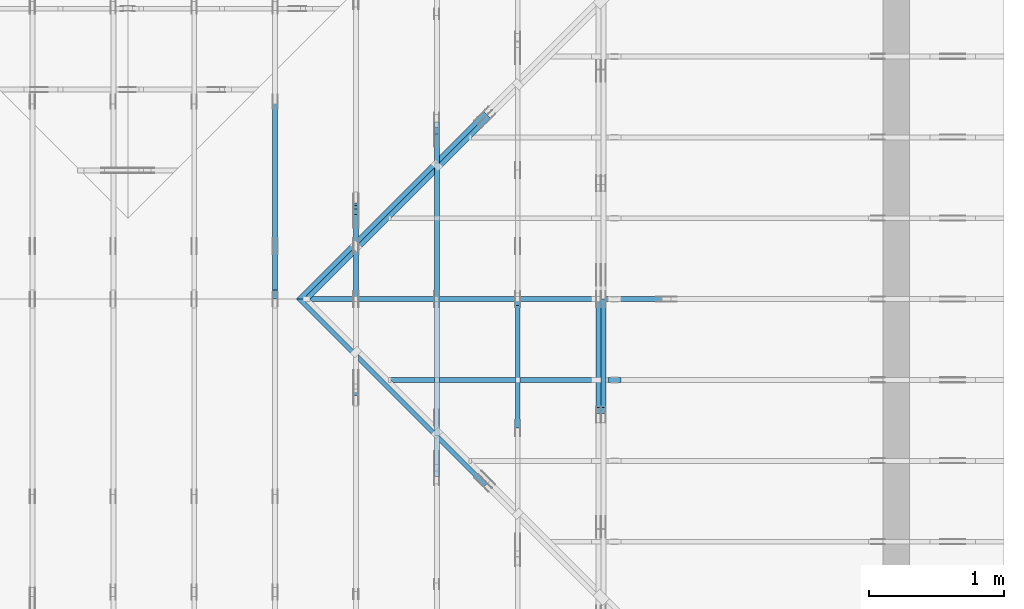
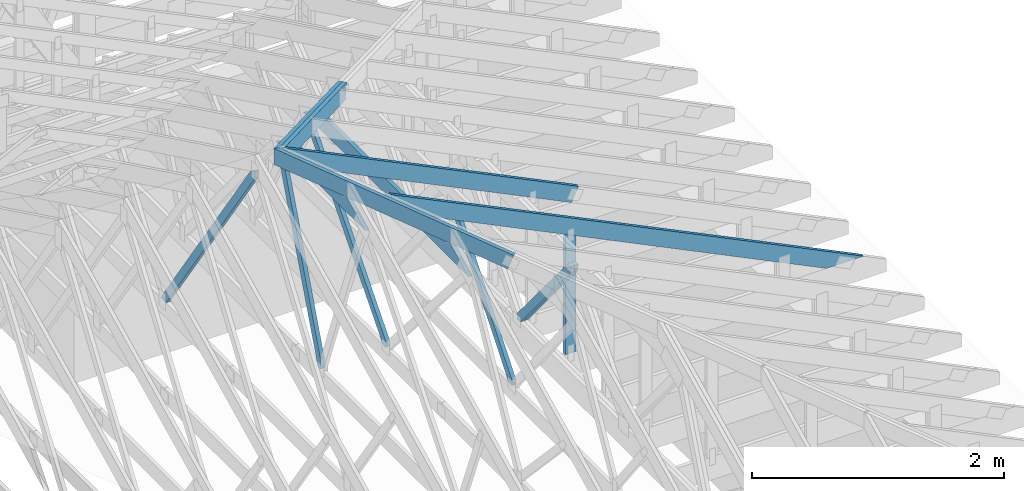
# One storey, part 32 of 159: 14 members, 9 elements without a shape of their own.
"""IFC2X3 building model written with IfcOpenShell, lengths in millimetres."""

from ifc_helpers import new_model, si_unit, frame, origin, origin_with_axes, origin_2d, place, context, project, spatial, faceted_brep, element, aggregate, save


model = new_model("IFC2X3")

# Units and contexts
model_context = context("Model", 3, precision=1e-05, world=origin())
plan_context = context("Plan", 2, precision=1e-05, world=origin_2d())
ifc_project = project(units=[si_unit("LENGTHUNIT", "METRE", prefix="MILLI"), si_unit("AREAUNIT", "SQUARE_METRE"), si_unit("VOLUMEUNIT", "CUBIC_METRE"), si_unit("SOLIDANGLEUNIT", "STERADIAN"), si_unit("PLANEANGLEUNIT", "RADIAN"), si_unit("MASSUNIT", "GRAM"), si_unit("TIMEUNIT", "SECOND"), si_unit("THERMODYNAMICTEMPERATUREUNIT", "DEGREE_CELSIUS"), si_unit("LUMINOUSINTENSITYUNIT", "LUMEN")], contexts=[model_context, plan_context])

# Site, building, storey
site_placement = place(None, origin_with_axes())
site = spatial("IfcSite", under=ifc_project, at=site_placement, CompositionType="ELEMENT")
building_placement = place(site_placement, origin_with_axes())
building = spatial("IfcBuilding", under=site, at=building_placement, Name="Plan 1", CompositionType="ELEMENT")
storey_placement = place(building_placement, origin_with_axes())
storey = spatial("IfcBuildingStorey", under=building, at=storey_placement, Name="Etasje 1", CompositionType="ELEMENT", Elevation=0.0)

# Assembly, members
assembly_1_placement = place(storey_placement, frame((16311.022261404749, -699.9989301294839, 1.1021457184401395e-15), z_axis=(1.0, -6.123031769111886e-17, 6.123031769111886e-17), x_axis=(6.123031769111886e-17, 1.0, 0.0)))
assembly_1 = element("IfcElementAssembly", 1, at=assembly_1_placement, inside=storey, Name="V8 (33)", AssemblyPlace="FACTORY", PredefinedType="TRUSS")
member_1_placement = place(assembly_1_placement, frame((4485.54541015625, 2143.08154296875, -36.0), z_axis=(0.0, 0.0, 1.0), x_axis=(1.0, 0.0, 0.0)))
member_1 = element("IfcMember", 2, at=member_1_placement, Name="V8-O63", context=model_context, shape_type="Brep", body=[
    faceted_brep([(1125.462890625, 148.0, 36.0), (303.44482421875, 148.0, 36.0), (0.0, 0.0, 36.0), (1428.908203125, 0.0, 36.0), (303.44482421875, 148.0, 3.7160045977279563e-14), (1125.462890625, 148.0, 1.3782490068506742e-13), (1428.908203125, 0.0, 1.749850064575791e-13), (0.0, 0.0, 0.0), (3.2373238346459116e-05, 5.9655634703700944e-05, 1.1819763087913658e-30), (3.237323834742541e-05, 5.965563470171974e-05, 36.0), (303.4450009271386, 148.00005965562735, 36.0), (303.4450009271386, 148.00005965562735, -3.867266952171377e-30), (1428.9080774456816, 5.965563442387334e-05, 1.6071579945459366e-29), (1428.9080774456816, 5.965563442607763e-05, 36.0), (3.237323835492134e-05, 5.965563468855511e-05, 36.0), (3.237323835492134e-05, 5.9655634686350816e-05, 0.0), (1125.4631088921742, 148.0000596556347, -2.9171847805096262e-30), (1125.4631088921742, 148.0000596556347, 36.0), (1428.9080774456816, 5.965563468635082e-05, 36.0), (1428.9080774456816, 5.965563468635082e-05, -3.957536578685919e-30), (303.4450009271386, 148.00005965562738, -1.5777218104420236e-30), (303.4450009271386, 148.00005965562738, 36.0), (1125.4631088921742, 148.00005965563463, 36.0), (1125.4631088921742, 148.00005965563463, -3.1554436208840472e-30)], [[[0, 1, 2, 3]], [[4, 5, 6, 7]], [[8, 9, 10, 11]], [[12, 13, 14, 15]], [[16, 17, 18, 19]], [[20, 21, 22, 23]]]),
])
member_2_placement = place(assembly_1_placement, frame((5833.009312431348, 2155.9421876756605, -36.0), z_axis=(0.0, 0.0, 1.0), x_axis=(-0.3523447959252878, -0.9358702606581573, 0.0)))
member_2 = element("IfcMember", 3, at=member_2_placement, Name="V8-D18", context=model_context, shape_type="Brep", body=[
    faceted_brep([(1879.7702283627486, 72.99989776441817, 36.0), (20.98469590610557, 72.99989776441817, 36.0), (9.808105369302211e-05, 36.49990879529287, 36.0), (13.7418892088549, 5.469382358569419e-05, 36.0), (1796.5636232285779, 5.469382358569419e-05, 36.0), (1893.5120194905498, 36.49990879529287, 36.0), (20.98469590610557, 72.99989776441817, 2.569799193964731e-15), (1879.7702283627486, 72.99989776441817, 2.301978565379163e-13), (1893.5120194905498, 36.49990879529287, 2.3188068501071683e-13), (1796.5636232285779, 5.469382358569419e-05, 2.200083228051868e-13), (13.7418892088549, 5.469382358569419e-05, 1.6828404838686871e-15), (9.808105369302211e-05, 36.49990879529287, 1.2011068154206862e-20), (5.329070518200751e-15, 36.50000000000909, -6.891536982014523e-31), (7.105427357601002e-15, 36.50000000000909, 36.0), (20.984613441527024, 73.00000000000635, 36.0), (20.984613441527024, 73.00000000000635, -1.0161066652788306e-30), (13.741846056984286, 5.4569682106375694e-12, -1.4920157537975556e-32), (13.741846056984288, 5.4578563890572696e-12, 36.0), (1.7763568394002505e-15, 36.5000000000091, 36.0), (0.0, 36.5000000000091, 6.653747496681012e-33), (1796.5636350754794, 3.820104426850659e-13, -2.339062076693153e-29), (1796.5636350754794, 3.842147341219462e-13, 36.0), (13.741846056984286, 5.462094485238892e-12, 36.0), (13.741846056984286, 5.459890193802012e-12, -1.7891395744689698e-31), (1893.5120359291654, 36.50000000000466, 5.679798517591285e-29), (1893.5120359291654, 36.50000000000466, 36.0), (1796.5636350754796, -7.958078640513122e-13, 36.0), (1796.5636350754796, -7.958078640513122e-13, 5.679798517591285e-29), (1879.770189872185, 72.99999999999909, 2.3413118293040299e-29), (1879.770189872185, 72.99999999999909, 36.0), (1893.5120359291657, 36.50000000000546, 36.0), (1893.5120359291657, 36.50000000000546, 1.067116229131686e-29), (20.984613441527014, 73.00000000000637, 7.888609052210118e-31), (20.984613441527014, 73.00000000000637, 36.0), (1879.7701898721843, 72.99999999999923, 36.0), (1879.7701898721843, 72.99999999999925, 9.466330862652142e-30)], [[[0, 1, 2, 3, 4, 5]], [[6, 7, 8, 9, 10, 11]], [[12, 13, 14, 15]], [[16, 17, 18, 19]], [[20, 21, 22, 23]], [[24, 25, 26, 27]], [[28, 29, 30, 31]], [[32, 33, 34, 35]]]),
])
aggregate(assembly_1, [member_1, member_2])

assembly_2_placement = place(storey_placement, frame((18074.541652722903, -699.9989301294845, 4.408582873760558e-15), z_axis=(-1.0, 1.836909530733566e-16, 6.123031769111886e-17), x_axis=(-1.836909530733566e-16, -1.0, 0.0)))
assembly_2 = element("IfcElementAssembly", 4, at=assembly_2_placement, inside=storey, Name="V5 (30)", AssemblyPlace="FACTORY", PredefinedType="TRUSS")
member_3_placement = place(assembly_2_placement, frame((-4378.102800312279, 1271.1402203108871, -36.00000000000001), z_axis=(0.0, 0.0, 1.0), x_axis=(-0.6383914022223919, -0.7697119055650163, 0.0)))
member_3 = element("IfcMember", 5, at=member_3_placement, Name="V5-D37", context=model_context, shape_type="Brep", body=[
    faceted_brep([(1301.1850182179683, 73.00007531970095, 36.0), (56.727774327628595, 73.00007531970095, 36.0), (4.196449572191341e-05, 36.500054264041864, 36.0), (30.272824098105048, 0.0, 36.0), (1287.449555036539, 0.0, 36.0), (1331.4578003515785, 36.500054264041864, 36.0), (56.727774327628595, 73.00007531970095, 6.946919287981591e-15), (1301.1850182179683, 73.00007531970095, 1.5934394408082096e-13), (1331.4578003515785, 36.500054264041864, 1.6305116821569092e-13), (1287.449555036539, 0.0, 1.5766189053235382e-13), (30.272824098105048, 0.0, 3.707229273868662e-15), (4.196449572191341e-05, 36.500054264041864, 5.138998809600713e-21), (-3.552713678800501e-15, 36.50005696570406, -1.2171898228077904e-31), (-3.552713678800501e-15, 36.50005696570406, 36.0), (56.727590003940804, 73.00005696571043, 36.0), (56.727590003940804, 73.00005696571043, -9.318771919226709e-31), (30.272737127562777, 5.6965711337397806e-05, -1.1910450751691715e-31), (30.272737127562777, 5.696571133917416e-05, 36.0), (7.105427357601002e-15, 36.50005696570406, 36.0), (7.105427357601002e-15, 36.50005696570406, -4.184997796531326e-31), (1287.4495266360868, 5.696570663646831e-05, 9.396159304201839e-30), (1287.4495266360868, 5.69657066386726e-05, 36.0), (30.272737127562777, 5.696571133599378e-05, 36.0), (30.272737127562777, 5.696571133378949e-05, 2.2093877117490416e-31), (1331.4577705681372, 36.50005696571134, 0.0), (1331.4577705681372, 36.50005696571134, 36.0), (1287.4495266360868, 5.69657067899243e-05, 36.0), (1287.4495266360868, 5.69657067899243e-05, 0.0), (1301.1850334405897, 73.000056965706, 0.0), (1301.1850334405897, 73.000056965706, 36.0), (1331.4577705681374, 36.50005696571145, 36.0), (1331.4577705681374, 36.50005696571145, 1.262177448353619e-29), (56.727590003940804, 73.00005696571044, 1.5777218104420236e-30), (56.727590003940804, 73.00005696571044, 36.0), (1301.1850334405895, 73.00005696570622, 36.0), (1301.1850334405895, 73.00005696570622, 2.129924444096732e-29)], [[[0, 1, 2, 3, 4, 5]], [[6, 7, 8, 9, 10, 11]], [[12, 13, 14, 15]], [[16, 17, 18, 19]], [[20, 21, 22, 23]], [[24, 25, 26, 27]], [[28, 29, 30, 31]], [[32, 33, 34, 35]]]),
])
member_4_placement = place(assembly_2_placement, frame((-4378.102800312279, 1271.1402203108871, -72.00000000000001), z_axis=(0.0, 0.0, 1.0), x_axis=(-0.6383914022223919, -0.7697119055650163, 0.0)))
member_4 = element("IfcMember", 6, at=member_4_placement, Name="V5-D37", context=model_context, shape_type="Brep", body=[
    faceted_brep([(1301.1850182179683, 73.00007531970095, 36.0), (56.727774327628595, 73.00007531970095, 36.0), (4.196449572191341e-05, 36.500054264041864, 36.0), (30.272824098105048, 0.0, 36.0), (1287.449555036539, 0.0, 36.0), (1331.4578003515785, 36.500054264041864, 36.0), (56.727774327628595, 73.00007531970095, 6.946919287981591e-15), (1301.1850182179683, 73.00007531970095, 1.5934394408082096e-13), (1331.4578003515785, 36.500054264041864, 1.6305116821569092e-13), (1287.449555036539, 0.0, 1.5766189053235382e-13), (30.272824098105048, 0.0, 3.707229273868662e-15), (4.196449572191341e-05, 36.500054264041864, 5.138998809600713e-21), (-3.552713678800501e-15, 36.50005696570406, -1.2171898228077904e-31), (-3.552713678800501e-15, 36.50005696570406, 36.0), (56.727590003940804, 73.00005696571043, 36.0), (56.727590003940804, 73.00005696571043, -9.318771919226709e-31), (30.272737127562777, 5.6965711337397806e-05, -1.1910450751691715e-31), (30.272737127562777, 5.696571133917416e-05, 36.0), (7.105427357601002e-15, 36.50005696570406, 36.0), (7.105427357601002e-15, 36.50005696570406, -4.184997796531326e-31), (1287.4495266360868, 5.696570663646831e-05, 9.396159304201839e-30), (1287.4495266360868, 5.69657066386726e-05, 36.0), (30.272737127562777, 5.696571133599378e-05, 36.0), (30.272737127562777, 5.696571133378949e-05, 2.2093877117490416e-31), (1331.4577705681372, 36.50005696571134, 0.0), (1331.4577705681372, 36.50005696571134, 36.0), (1287.4495266360868, 5.69657067899243e-05, 36.0), (1287.4495266360868, 5.69657067899243e-05, 0.0), (1301.1850334405897, 73.000056965706, 0.0), (1301.1850334405897, 73.000056965706, 36.0), (1331.4577705681374, 36.50005696571145, 36.0), (1331.4577705681374, 36.50005696571145, 1.262177448353619e-29), (56.727590003940804, 73.00005696571044, 1.5777218104420236e-30), (56.727590003940804, 73.00005696571044, 36.0), (1301.1850334405895, 73.00005696570622, 36.0), (1301.1850334405895, 73.00005696570622, 2.129924444096732e-29)], [[[0, 1, 2, 3, 4, 5]], [[6, 7, 8, 9, 10, 11]], [[12, 13, 14, 15]], [[16, 17, 18, 19]], [[20, 21, 22, 23]], [[24, 25, 26, 27]], [[28, 29, 30, 31]], [[32, 33, 34, 35]]]),
])
aggregate(assembly_2, [member_3, member_4])

# Assembly, member
assembly_3_placement = place(storey_placement, frame((17475.02226140475, -699.9989301294827, 1.1021457184401395e-15), z_axis=(-1.0, 1.836909530733566e-16, 6.123031769111886e-17), x_axis=(-1.836909530733566e-16, -1.0, 0.0)))
assembly_3 = element("IfcElementAssembly", 7, at=assembly_3_placement, inside=storey, Name="V6 (31)", AssemblyPlace="FACTORY", PredefinedType="TRUSS")
member_5_placement = place(assembly_3_placement, frame((-5228.410058754339, 1534.887689035876, -36.0), z_axis=(0.0, 0.0, 1.0), x_axis=(0.6278034094771183, -0.7783719413294043, 0.0)))
member_5 = element("IfcMember", 8, at=member_5_placement, Name="V6-D28", context=model_context, shape_type="Brep", body=[
    faceted_brep([(1479.4702259563628, 72.99999232308619, 36.0), (29.439320426047743, 72.99999232308619, 36.0), (0.0, 36.49996297022972, 36.0), (45.25389095808168, 0.0, 36.0), (1495.28484399645, 0.0, 36.0), (1524.7241644224973, 36.49996297022972, 36.0), (29.439320426047743, 72.99999232308619, 3.605157884595096e-15), (1479.4702259563628, 72.99999232308619, 1.8117686389971902e-13), (1524.7241644224973, 36.49996297022972, 1.8671868995783053e-13), (1495.28484399645, 0.0, 1.8311353207323548e-13), (45.25389095808168, 0.0, 5.541820240245186e-15), (0.0, 36.49996297022972, 0.0), (2.8096437745261937e-05, 36.500000246796844, -2.212142430608751e-32), (2.8096437745261937e-05, 36.500000246796844, 36.0), (29.439455739188816, 73.00000024679548, 36.0), (29.439455739188816, 73.00000024679548, -1.2755299918183443e-31), (45.253964965309024, 2.4679638599423015e-07, 0.0), (45.253964965309024, 2.4679638599423015e-07, 36.0), (2.809643774881465e-05, 36.500000246796844, 36.0), (2.809643774881465e-05, 36.500000246796844, -1.9721522630525295e-31), (1495.2847442097918, 2.467986858827717e-07, 2.646057631629209e-29), (1495.2847442097918, 2.4679868808706315e-07, 36.0), (45.253964965309024, 2.467963786725069e-07, 36.0), (45.253964965309024, 2.4679637646821546e-07, 8.00814689476148e-31), (1524.7241718525415, 36.500000246797185, 1.262177448353619e-29), (1524.7241718525415, 36.500000246797185, 36.0), (1495.2847442097918, 2.467990043442114e-07, 36.0), (1495.2847442097918, 2.467990043442114e-07, 1.262177448353619e-29), (1479.4702349836316, 73.0000002467973, 0.0), (1479.4702349836316, 73.0000002467973, 36.0), (1524.7241718525415, 36.5000002467973, 36.0), (1524.7241718525415, 36.5000002467973, 0.0), (29.439455739188816, 73.00000024679548, -7.888609052210118e-31), (29.439455739188816, 73.00000024679547, 36.0), (1479.4702349836316, 73.00000024679731, 36.0), (1479.4702349836316, 73.00000024679731, 7.888609052210118e-31)], [[[0, 1, 2, 3, 4, 5]], [[6, 7, 8, 9, 10, 11]], [[12, 13, 14, 15]], [[16, 17, 18, 19]], [[20, 21, 22, 23]], [[24, 25, 26, 27]], [[28, 29, 30, 31]], [[32, 33, 34, 35]]]),
])
aggregate(assembly_3, [member_5])

# Assembly, members
assembly_4_placement = place(storey_placement, frame((16875.02226140475, -699.9989301294827, 1.1021457184401395e-15), z_axis=(-1.0, 1.836909530733566e-16, 6.123031769111886e-17), x_axis=(-1.836909530733566e-16, -1.0, 0.0)))
assembly_4 = element("IfcElementAssembly", 9, at=assembly_4_placement, inside=storey, Name="V7 (32)", AssemblyPlace="FACTORY", PredefinedType="TRUSS")
member_6_placement = place(assembly_4_placement, frame((-6514.45361328125, 1850.4420166015625, -36.0), z_axis=(0.0, 0.0, 1.0), x_axis=(1.0, 0.0, 0.0)))
member_6 = element("IfcMember", 10, at=member_6_placement, Name="V7-O44", context=model_context, shape_type="Brep", body=[
    faceted_brep([(2325.46337890625, 148.0, 36.0), (303.4453125, 148.0, 36.0), (0.0, 0.0, 36.0), (2628.908203125, 0.0, 36.0), (303.4453125, 148.0, 3.7160105772511684e-14), (2325.46337890625, 148.0, 2.847777229389848e-13), (2628.908203125, 0.0, 3.219377689162644e-13), (0.0, 0.0, 0.0), (0.00011629187794372442, 2.8305199493096712e-05, -1.9096372165266467e-30), (0.00011629187794469072, 2.830519949111551e-05, 36.0), (303.44508484525437, 148.00002830519955, 36.0), (303.44508484525437, 148.00002830519955, -9.429354888510868e-31), (2628.908180141676, 2.8305215382797386e-05, -8.019665763739227e-29), (2628.908180141676, 2.8305215385001678e-05, 36.0), (0.00011629187793005258, 2.8305199523332437e-05, 36.0), (0.00011629187793005258, 2.8305199521128146e-05, -3.385423730368188e-36), (2325.4632115877034, 148.0000283052143, 1.262177448353619e-29), (2325.4632115877034, 148.0000283052143, 36.0), (2628.908180141676, 2.8305214527790667e-05, 36.0), (2628.908180141676, 2.8305214527790667e-05, 2.524354896707238e-29), (303.44508484525426, 148.0000283051996, 4.733165431326071e-30), (303.44508484525426, 148.0000283051996, 36.0), (2325.463211587703, 148.00002830521476, 36.0), (2325.463211587703, 148.00002830521476, 4.1020767071492614e-29)], [[[0, 1, 2, 3]], [[4, 5, 6, 7]], [[8, 9, 10, 11]], [[12, 13, 14, 15]], [[16, 17, 18, 19]], [[20, 21, 22, 23]]]),
])
member_7_placement = place(assembly_4_placement, frame((-6500.796372209361, 1826.6337940301255, -36.0), z_axis=(0.0, 0.0, 1.0), x_axis=(0.6522779004065171, -0.7579799078084232, 0.0)))
member_7 = element("IfcMember", 11, at=member_7_placement, Name="V7-D16", context=model_context, shape_type="Brep", body=[
    faceted_brep([(1909.4073766005222, 73.00012215480956, 36.0), (31.410068926799795, 73.00012215480956, 36.0), (8.526562305632979e-05, 36.50022051372298, 36.0), (14.249919182940175, 0.0, 36.0), (1920.4122303568074, 0.0, 36.0), (1951.8222140179846, 36.50022051372298, 36.0), (31.410068926799795, 73.00012215480956, 3.846496998175785e-15), (1909.4073766005222, 73.00012215480956, 2.338272405420316e-13), (1951.8222140179846, 36.50022051372298, 2.390213884818084e-13), (1920.4122303568074, 0.0, 2.3517490192531493e-13), (14.249919182940175, 0.0, 1.7450541572883917e-15), (8.526562305632979e-05, 36.50022051372298, 1.0441682375740524e-20), (-2.1316282072803006e-14, 36.50016482514458, 1.748229112765794e-30), (-2.1316282072803006e-14, 36.50016482514458, 36.0), (31.40999269186427, 73.00016482515096, 36.0), (31.40999269186427, 73.00016482515096, 3.622724775901187e-30), (14.250083227569121, 0.00016482515093230177, 1.596921892448502e-32), (14.250083227569123, 0.00016482515093318995, 36.0), (8.881784197001252e-15, 36.500164825144566, 36.0), (7.105427357601002e-15, 36.500164825144566, -4.005958516626654e-31), (1920.4122517577107, 0.0001648251488908687, -1.4224027826644845e-29), (1920.4122517577107, 0.00016482514889307298, 36.0), (14.250083227569121, 0.0001648251509362298, 36.0), (14.250083227569121, 0.0001648251509340255, -1.0554697948349673e-31), (1951.8222444495666, 36.5001648251515, 4.247031804602483e-29), (1951.8222444495666, 36.5001648251515, 36.0), (1920.4122517577114, 0.00016482514797644399, 36.0), (1920.4122517577114, 0.00016482514797644399, 4.276709189871815e-29), (1909.4073985414311, 73.000164825149, 2.524354896707238e-29), (1909.4073985414311, 73.000164825149, 36.0), (1951.822244449566, 36.50016482515264, 36.0), (1951.822244449566, 36.50016482515264, 1.262177448353619e-29), (31.409992691864318, 73.00016482515093, 0.0), (31.409992691864318, 73.00016482515093, 36.0), (1909.4073985414311, 73.00016482514873, 36.0), (1909.4073985414311, 73.00016482514874, 3.944304526105059e-30)], [[[0, 1, 2, 3, 4, 5]], [[6, 7, 8, 9, 10, 11]], [[12, 13, 14, 15]], [[16, 17, 18, 19]], [[20, 21, 22, 23]], [[24, 25, 26, 27]], [[28, 29, 30, 31]], [[32, 33, 34, 35]]]),
])
aggregate(assembly_4, [member_6, member_7])

# Assembly, member
assembly_5_placement = place(storey_placement, frame((21100.012663101486, 4518.000534935253, 1.1021457184401395e-15), z_axis=(1.2246063538223773e-16, 1.0, 6.123031769111886e-17), x_axis=(-1.0, 1.2246063538223773e-16, 0.0)))
assembly_5 = element("IfcElementAssembly", 12, at=assembly_5_placement, inside=storey, Name="S13 (51)", AssemblyPlace="FACTORY", PredefinedType="TRUSS")
member_8_placement = place(assembly_5_placement, frame((2535.5603799786395, 1192.010340223969, -36.00000424921966), z_axis=(0.0, 0.0, 1.0), x_axis=(0.8987940462991673, 0.4383711467890768, 0.0)))
member_8 = element("IfcMember", 13, at=member_8_placement, Name="S13-O37", context=model_context, shape_type="Brep", body=[
    faceted_brep([(2980.0000763953276, 148.00000015988064, 18.000004249218136), (2907.8156524442757, 5.343159159565403e-06, 18.000001219009846), (2887.7888160004172, 5.017061084799934e-06, 0.0), (2959.973241424066, 148.0000003204675, 4.140420969633851e-06), (2907.8156528472914, 1.6059462990847113e-07, 18.000004249219657), (2887.7888183593773, 1.6059417905383586e-07, 36.00000424921966), (1.8189894035458565e-12, 1.6059470951451615e-07, 36.00000424921966), (1.8189894035458565e-12, 1.6059561858128333e-07, 4.249219657026515e-06), (2887.7888183593773, 1.6059508812060303e-07, 4.249219657026515e-06), (2980.0000787543404, 147.99999530338243, 18.000000000006366), (2959.973242310477, 147.99999497729357, 36.000001219010755), (2887.788818359376, 1.605960733286338e-07, 36.00000424921973), (2907.815653330642, 3.410605131648481e-13, 18.0000041404287), (7.639532714165398e-05, 148.00000015988053, 4.249218903851215e-06), (7.639532714165398e-05, 148.00000015988053, 36.000004249218904), (2959.973241907412, 148.00000015988036, 36.000004249218904), (2980.000076395327, 148.00000015988036, 18.000004249218907), (2959.973241907412, 148.00000015988036, 4.249218903851215e-06), (7.639532577741193e-05, 5.354052063921699e-07, 4.175232156455877e-06), (7.639532623525175e-05, 5.354052063921699e-07, 36.00000424921966), (7.639532671345236e-05, 148.0000033106544, 36.000004850292726), (7.639532625561251e-05, 148.0000033106544, 2.296878491847565e-06), (2959.9732437133785, 148.00000016059585, 36.00000424921966), (0.0, 148.00000016059585, 36.00000424921966), (0.0, 1.5973455447237939e-07, 36.00000424921966), (2887.7888183593755, 1.5973455447237939e-07, 36.00000424921966), (9.693552465250832e-05, 148.00000015973433, 4.249219657026527e-06), (2959.9732414667737, 148.00000015973433, 4.249220019506719e-06), (2887.7888161127707, 1.5987961887731217e-07, 4.2492200106669684e-06), (9.693552465250832e-05, 1.5987961887731217e-07, 4.249219657026527e-06)], [[[0, 1, 2, 3]], [[4, 5, 6, 7, 8]], [[9, 10, 11, 12]], [[13, 14, 15, 16, 17]], [[18, 19, 20, 21]], [[22, 23, 24, 25]], [[26, 27, 28, 29]]]),
])
aggregate(assembly_5, [member_8])

# Assembly, members
assembly_6_placement = place(storey_placement, frame((21100.012663101486, 3918.0074014212582, 1.1021457184401395e-15), z_axis=(1.2246063538223773e-16, 1.0, 6.123031769111886e-17), x_axis=(-1.0, 1.2246063538223773e-16, 0.0)))
assembly_6 = element("IfcElementAssembly", 14, at=assembly_6_placement, inside=storey, Name="S14 (43)", AssemblyPlace="FACTORY", PredefinedType="TRUSS")
member_9_placement = place(assembly_6_placement, frame((276.06008258286386, 89.97841148626176, -36.00000021758279), z_axis=(0.0, 0.0, 1.0), x_axis=(0.8987940462991673, 0.43837114678907685, 0.0)))
member_9 = element("IfcMember", 15, at=member_9_placement, Name="S14-O8", context=model_context, shape_type="Brep", body=[
    faceted_brep([(4846.397802857356, 147.99999481741781, 36.0000032477883), (4774.21337890625, 7.227072273963131e-10, 36.00000021758251), (4734.159708963717, 3.2191519494517706e-07, 0.0), (4806.344132914822, 147.99999513861042, 3.0302048799057957e-06), (0.00034107614584399926, 148.00000000000122, 2.1758278734296255e-07), (0.00034107614584399926, 148.000000000001, 36.00000021758279), (4846.397802013646, 148.00000000000068, 36.00000021758279), (4806.3441330378155, 148.00000000000094, 2.1758278734296255e-07), (0.0003821565456405551, 147.99999999990047, 2.1758278734300935e-07), (4806.344132156545, 147.99999999990047, 2.1758337593091884e-07), (4734.159706802541, 2.2737367544323206e-13, 2.1758336709116825e-07), (303.44520637529575, 2.2737367544323206e-13, 2.1758282450305532e-07), (303.4451274623483, 5.691447313438402e-10, 2.1758278734296255e-07), (303.4451274623483, 5.691447313438402e-10, 36.00000021758279), (0.0001557492167307828, 148.0000015415092, 36.00000021758279), (0.0001557492167307828, 148.0000015415092, 2.1758278734296255e-07), (4774.21337802498, 7.201714254888537e-10, 36.00000021758279), (303.44535358039997, 7.209926651282338e-10, 36.00000021758279), (303.44535358039997, 7.214460963661031e-10, 2.1758278734296255e-07), (4734.15970904915, 7.206322142233512e-10, 2.1758278734296255e-07), (4846.397804260254, 148.00000000072282, 36.00000021758279), (0.0, 148.00000000072282, 36.00000021758279), (303.44531250000017, 5.690310445061186e-10, 36.00000021758279), (4774.21337890625, 5.690310445061186e-10, 36.00000021758279)], [[[0, 1, 2, 3]], [[4, 5, 6, 7]], [[8, 9, 10, 11]], [[12, 13, 14, 15]], [[16, 17, 18, 19]], [[20, 21, 22, 23]]]),
])
member_10_placement = place(assembly_6_placement, frame((2840.9904016985674, 1388.7763671875, -36.0), z_axis=(0.0, 0.0, 1.0), x_axis=(-1.836909530733566e-16, -1.0, 0.0)))
member_10 = element("IfcMember", 16, at=member_10_placement, Name="S14-S8", context=model_context, shape_type="Brep", body=[
    faceted_brep([(1165.7763671875, 98.00007681705802, 36.0), (0.0, 98.00007681705802, 36.0), (47.7978515625, 7.681705756112933e-05, 36.0), (1165.7763671875, 7.681705756112933e-05, 36.0), (0.0, 98.00007681705802, 0.0), (1165.7763671875, 98.00007681705802, 1.4276171463937812e-13), (1165.7763671875, 7.681705756112933e-05, 1.4276171463937812e-13), (47.7978515625, 7.681705756112933e-05, 5.853355272249634e-15), (47.79785166725196, -7.105427357601002e-15, 3.944304526105059e-31), (47.79785166725196, -7.105427357601002e-15, 36.0), (5.798778148147221e-05, 98.00000000001457, 36.0), (5.798778148147221e-05, 98.00000000001457, -3.944304526105059e-31), (1165.776367187592, -2.335847581209805e-13, 4.214679371152369e-29), (1165.776367187592, -2.313804666841002e-13, 36.0), (47.79785166725196, -2.6017927652632522e-14, 36.0), (47.79785166725196, -2.82222190895128e-14, 1.728055440799228e-30), (1165.776367187592, 97.9999999999859, 3.736045247126712e-27), (1165.776367187592, 97.9999999999859, 36.0), (1165.776367187592, 4.547473508864641e-13, 36.0), (1165.776367187592, 4.547473508864641e-13, 0.0), (5.7987781474366784e-05, 98.00000000001455, 0.0), (5.7987781474366784e-05, 98.00000000001455, 36.0), (1165.7763671875312, 97.999999999986, 36.0), (1165.7763671875312, 97.999999999986, 6.310887241768095e-30)], [[[0, 1, 2, 3]], [[4, 5, 6, 7]], [[8, 9, 10, 11]], [[12, 13, 14, 15]], [[16, 17, 18, 19]], [[20, 21, 22, 23]]]),
])
aggregate(assembly_6, [member_9, member_10])

assembly_7_placement = place(storey_placement, frame((21074.556818978763, 9725.45584412271, 2.204291436880279e-15), z_axis=(-0.7071067811865471, 0.7071067811865479, 6.123031769111886e-17), x_axis=(-0.7071067811865479, -0.7071067811865471, 0.0)))
assembly_7 = element("IfcElementAssembly", 17, at=assembly_7_placement, inside=storey, Name="GR1 (36)", AssemblyPlace="FACTORY", PredefinedType="TRUSS")
member_11_placement = place(assembly_7_placement, frame((5468.934472527259, 1837.15067168082, -36.00000195234122), z_axis=(0.0, 0.0, 1.0), x_axis=(0.9453579955214152, 0.32603413978252627, 0.0)))
member_11 = element("IfcMember", 18, at=member_11_placement, Name="GR1-O54.1", context=model_context, shape_type="Brep", body=[
    faceted_brep([(2083.0503962584403, 147.9999985520343, 36.00000161312175), (2032.0083021287082, 2.5400458980584517e-07, 36.000001952340654), (1993.9274905928764, -5.684341886080802e-14, 2.374089717704919e-06), (2044.969584722609, 147.99999467122717, 3.2173327326745493e-06), (0.00010423583262308966, 148.00000025501186, 1.952341222022369e-06), (0.00010423583262308966, 148.0000002550114, 36.00000195234122), (2083.0503972045826, 148.00000025501126, 36.00000195234122), (2044.9695866577076, 148.00000025501174, 1.952341222022369e-06), (0.00010288836710969917, 148.0000002568213, 1.9523412220223817e-06), (2044.9695853102412, 148.0000002568213, 1.952341472450644e-06), (1993.927490125915, 2.550445969973225e-07, 1.9523414661999965e-06), (0.00010288836620020447, 2.550445969973225e-07, 1.9523412220223817e-06), (5.143132966622943e-05, 6.324914920696756e-07, 1.8783537143463036e-06), (5.1431328757162663e-05, 6.324914920696756e-07, 36.00000195234122), (5.1431328775286824e-05, 148.0000034077409, 36.00000255341424), (5.143132968435365e-05, 148.0000034077409, 4.576700956714107e-28), (2032.00830078125, 2.5405696944129813e-07, 36.00000195234122), (4.0490841685084796e-31, 2.5405734270283954e-07, 36.00000195234122), (2.195887084695885e-38, 2.540573404985481e-07, 1.952341222022369e-06), (1993.927490234375, 2.5405697423210706e-07, 1.952341222022369e-06), (2083.0503973130335, 148.0000002540046, 36.00000195234122), (1.347457327938173e-06, 148.0000002540046, 36.00000195234122), (1.347457327938173e-06, 2.568210675235605e-07, 36.00000195234122), (2032.0083021287082, 2.568210675235605e-07, 36.00000195234122)], [[[0, 1, 2, 3]], [[4, 5, 6, 7]], [[8, 9, 10, 11]], [[12, 13, 14, 15]], [[16, 17, 18, 19]], [[20, 21, 22, 23]]]),
])
member_12_placement = place(assembly_7_placement, frame((5468.934471253674, 1837.1506712415191, -72.00000195234122), z_axis=(0.0, 0.0, 1.0), x_axis=(0.9453579955214152, 0.32603413978252627, 0.0)))
member_12 = element("IfcMember", 19, at=member_12_placement, Name="GR1-O54.1", context=model_context, shape_type="Brep", body=[
    faceted_brep([(2044.9695857111403, 147.99999855221665, 36.00000161302728), (1993.9274915815952, 2.5412197146579274e-07, 36.00000195234111), (1955.8466800458955, -5.684341886080802e-14, 2.373949655520846e-06), (2006.8887741754406, 147.99999467129197, 3.21709717354679e-06), (0.00010423558524053078, 148.0000002551094, 1.952341222022369e-06), (0.00010423558524053078, 148.0000002551094, 36.00000195234123), (2044.9695866574612, 148.00000025510928, 36.00000195234123), (2006.8887761105862, 148.00000025510928, 1.952341222022369e-06), (0.00010288836074323626, 148.00000025688564, 1.9523412220223817e-06), (2006.8887747633598, 148.00000025688564, 1.9523414677872435e-06), (1955.8466795790337, 2.551423676777631e-07, 1.952341461536596e-06), (0.00010288836074323626, 2.551423676777631e-07, 1.9523412220223817e-06), (5.277854961605044e-05, 6.325560661935015e-07, 1.8783537143463036e-06), (5.2778548706983674e-05, 6.325560661935015e-07, 36.00000195234122), (5.2778548725107834e-05, 148.00000340780548, 36.00000255341424), (5.277854963417466e-05, 148.00000340780548, 4.576700956714107e-28), (1993.927490234375, 2.541749842621318e-07, 36.00000195234122), (8.410103301840838e-29, 2.5417535052857284e-07, 36.00000195234122), (-1.1754943508222875e-38, 2.541748926887521e-07, 1.952341222022369e-06), (1955.8466796875, 2.5417453341741147e-07, 1.952341222022369e-06), (2044.9695867659202, 148.00000025412191, 36.00000195234122), (1.3472181308316067e-06, 148.00000025412191, 36.00000195234122), (1.3472190403263085e-06, 2.568851869000355e-07, 36.00000195234122), (1993.927491581595, 2.568851869000355e-07, 36.00000195234122)], [[[0, 1, 2, 3]], [[4, 5, 6, 7]], [[8, 9, 10, 11]], [[12, 13, 14, 15]], [[16, 17, 18, 19]], [[20, 21, 22, 23]]]),
])
aggregate(assembly_7, [member_11, member_12])

# Assembly, member
assembly_8_placement = place(storey_placement, frame((21125.46850722421, -674.5430860067681, 2.204291436880279e-15), z_axis=(0.707106781186546, 0.707106781186549, 6.123031769111886e-17), x_axis=(-0.707106781186549, 0.707106781186546, 0.0)))
assembly_8 = element("IfcElementAssembly", 20, at=assembly_8_placement, inside=storey, Name="GR1 (35)", AssemblyPlace="FACTORY", PredefinedType="TRUSS")
member_13_placement = place(assembly_8_placement, frame((5468.934472444405, 1837.150671920932, -72.00000195234122), z_axis=(0.0, 0.0, 1.0), x_axis=(0.9453579955214152, 0.32603413978252627, 0.0)))
member_13 = element("IfcMember", 21, at=member_13_placement, Name="GR1-O54.1", context=model_context, shape_type="Brep", body=[
    faceted_brep([(2083.050395899972, 148.00000217886947, 3.895764962180692e-06), (2044.9695843641257, 147.99999829807695, 36.000002291538294), (1993.927490234375, 5.3148596634855494e-11, 36.00000195234122), (2032.0083017702218, 2.540422769925499e-07, 2.3741058612358756e-06), (0.00010288836801919388, 148.00000000104023, 1.952341222022369e-06), (0.00010288836801919388, 148.00000000104023, 36.00000195234122), (2044.969585310243, 148.00000000104012, 36.00000195234122), (2083.050395857119, 148.00000000104012, 1.952341222022369e-06), (5.143137059349101e-05, 3.784869022638304e-07, 1.8783537143463036e-06), (5.143136968442424e-05, 3.784869022638304e-07, 36.00000195234122), (5.1431369702548404e-05, 148.00000315373632, 36.00000255341424), (5.143137061161523e-05, 148.00000315373632, 4.576700956714107e-28), (2032.0083021287492, -3.7326154155146056e-13, 1.952341222022369e-06), (1993.9274915818733, -3.6406214973141873e-13, 36.00000195234122), (1.3474982551997527e-06, 2.2042913088995137e-15, 36.00000195234122), (1.3474982551997527e-06, -1.2798076549643078e-22, 1.952341222022369e-06), (2044.9695854187012, 148.0000000000532, 36.00000195234122), (0.0, 148.0000000000532, 36.00000195234122), (0.0, 2.816022970364429e-09, 36.00000195234122), (1993.927490234375, 2.816022970364429e-09, 36.00000195234122), (0.00010423587264085654, 148.00000000281625, 1.9523412220223817e-06), (2083.0503972046236, 148.00000000281625, 1.952341477114044e-06), (2032.0083020202965, 1.0068106348626316e-09, 1.952341470863397e-06), (0.00010423587355035124, 1.0068106348626316e-09, 1.9523412220223817e-06)], [[[0, 1, 2, 3]], [[4, 5, 6, 7]], [[8, 9, 10, 11]], [[12, 13, 14, 15]], [[16, 17, 18, 19]], [[20, 21, 22, 23]]]),
])
aggregate(assembly_8, [member_13])

assembly_9_placement = place(storey_placement, frame((15675.02226140475, -699.9989301294845, 1.1021457184401395e-15), z_axis=(-1.0, 1.836909530733566e-16, 6.123031769111886e-17), x_axis=(-1.836909530733566e-16, -1.0, 0.0)))
assembly_9 = element("IfcElementAssembly", 22, at=assembly_9_placement, inside=storey, Name="T7 (111)", AssemblyPlace="FACTORY", PredefinedType="TRUSS")
member_14_placement = place(assembly_9_placement, frame((-5230.134196319675, 2512.1392759871583, -36.0), z_axis=(0.0, 0.0, 1.0), x_axis=(-0.5642475050074617, -0.8256056886267528, 0.0)))
member_14 = element("IfcMember", 23, at=member_14_placement, Name="T7-D10", context=model_context, shape_type="Brep", body=[
    faceted_brep([(2543.5256108538483, 72.99999048793325, 36.0), (53.406771110820955, 72.99999048793325, 36.0), (0.0, 36.50009322373626, 36.0), (64.12142578860312, 0.00011835360965051223, 36.0), (2593.4163311647717, 0.00011835360965051223, 36.0), (53.406771110820955, 72.99999048793325, 6.5402271239448724e-15), (2543.5256108538483, 72.99999048793325, 3.114817624161566e-13), (2593.4163311647717, 0.00011835360965051223, 3.175914117251098e-13), (64.12142578860312, 0.00011835360965051223, 7.852350543687342e-15), (0.0, 36.50009322373626, 0.0), (3.72532881449672e-05, 36.50017519275116, 3.944304526105059e-31), (3.72532881449672e-05, 36.50017519275116, 36.0), (53.40675570041866, 73.00017519218363, 36.0), (53.40675570041866, 73.00017519218363, 7.888609052210118e-31), (64.12144158709383, 0.00017519218362238576, 7.888609052210118e-31), (64.12144158709383, 0.00017519218362593847, 36.0), (3.7253288159178055e-05, 36.500175192751165, 36.0), (3.72532881574017e-05, 36.500175192751165, -3.944304526105059e-31), (2593.4162114323694, 0.0001751921831566568, 2.916933296842317e-29), (2593.4162114323694, 0.00017519218315886108, 36.0), (64.12144158709384, 0.00017519218362346966, 36.0), (64.12144158709384, 0.00017519218362126537, 7.212035881277958e-31), (2543.52548462057, 73.00017519218363, -8.473528143218631e-30), (2543.52548462057, 73.00017519218363, 36.0), (2593.41621143237, 0.00017519218386041757, 36.0), (2593.41621143237, 0.00017519218386041757, -9.018458054926462e-30), (53.40675570041867, 73.00017519218363, 0.0), (53.40675570041867, 73.00017519218363, 36.0), (2543.52548462057, 73.00017519218348, 36.0), (2543.52548462057, 73.00017519218348, -9.466330862652142e-30)], [[[0, 1, 2, 3, 4]], [[5, 6, 7, 8, 9]], [[10, 11, 12, 13]], [[14, 15, 16, 17]], [[18, 19, 20, 21]], [[22, 23, 24, 25]], [[26, 27, 28, 29]]]),
])
aggregate(assembly_9, [member_14])

save(model, "model.ifc")
